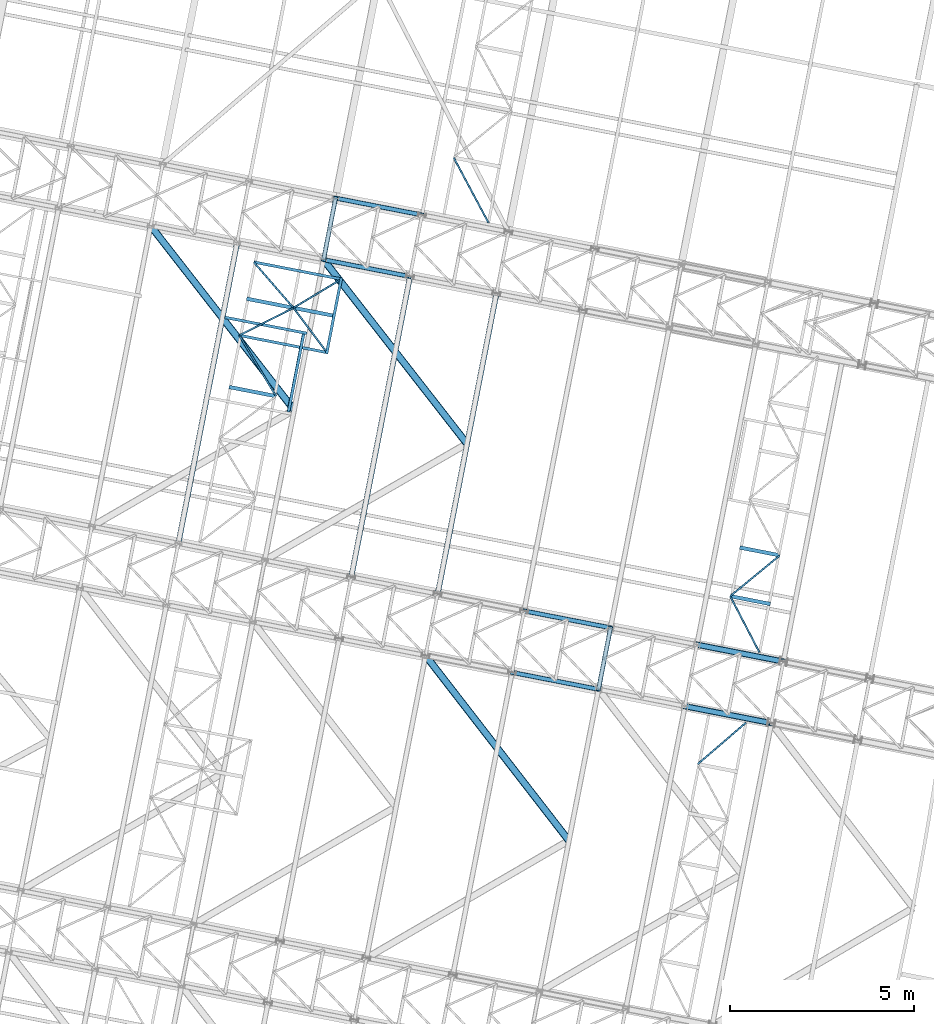
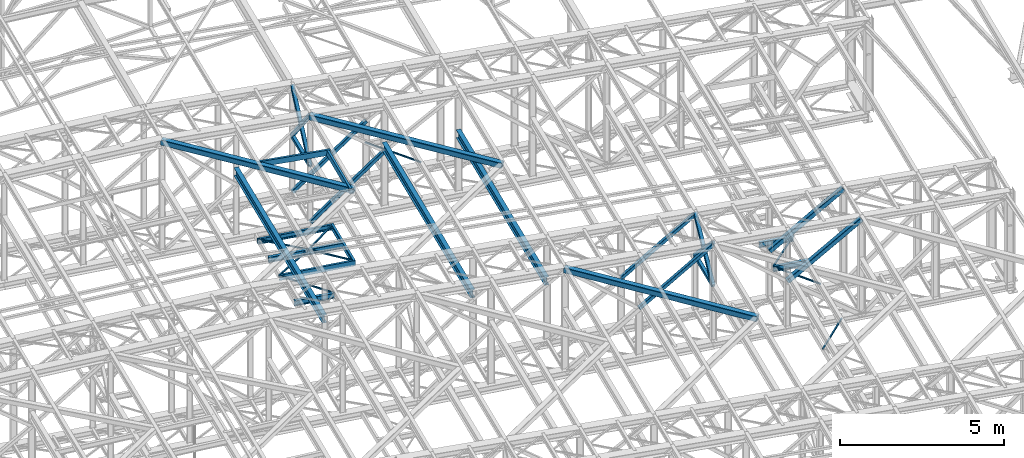
# One storey, part 91 of 215: 26 beams, 10 members, 36 elements without a shape of their own.
"""IFC2X3 building model written with IfcOpenShell, lengths in millimetres."""

from ifc_helpers import new_model, si_unit, frame, origin_with_axes, origin_2d_with_axis, place, context, subcontext, project, spatial, hollow_rectangle, i_section, u_section, extrude, material, type_object, element, aggregate, save


model = new_model("IFC2X3")

# Units and contexts
model_context = context("Model", 3, precision=1e-05, world=origin_with_axes())
body_context = subcontext(model_context, "Body", "Model", "MODEL_VIEW")
ifc_project = project(units=[si_unit("LENGTHUNIT", "METRE", prefix="MILLI"), si_unit("AREAUNIT", "SQUARE_METRE"), si_unit("VOLUMEUNIT", "CUBIC_METRE"), si_unit("MASSUNIT", "GRAM", prefix="KILO"), si_unit("TIMEUNIT", "SECOND"), si_unit("PLANEANGLEUNIT", "RADIAN"), si_unit("SOLIDANGLEUNIT", "STERADIAN"), si_unit("THERMODYNAMICTEMPERATUREUNIT", "DEGREE_CELSIUS"), si_unit("LUMINOUSINTENSITYUNIT", "LUMEN")], contexts=[model_context])

# Site, building, storey
site_placement = place(None, origin_with_axes())
site = spatial("IfcSite", under=ifc_project, at=site_placement, CompositionType="ELEMENT")
building_placement = place(site_placement, origin_with_axes())
building = spatial("IfcBuilding", under=site, at=building_placement, Name="Undefined", CompositionType="ELEMENT")
storey_placement = place(building_placement, origin_with_axes())
storey = spatial("IfcBuildingStorey", under=building, at=storey_placement, Name="Undefined", CompositionType="ELEMENT", Elevation=0.0)

# Assembly, beam
assembly_1_placement = place(storey_placement, origin_with_axes())
assembly_1 = element("IfcElementAssembly", 1, at=assembly_1_placement, inside=storey, Name="Steel Assembly", AssemblyPlace="NOTDEFINED", PredefinedType="RIGID_FRAME")
ifc_material_1 = material(Name="STEEL/S275JR")
beam_type_1 = type_object("IfcBeamType", PredefinedType="NOTDEFINED")
beam_1_placement = place(assembly_1_placement, frame((85110.1188947794, 34374.6074251292, 10796.000000583), z_axis=(0.981422364268518, -0.191859461052493, -0.000300197000082615), x_axis=(0.191859470081235, 0.981422408415534, 0.0)))
beam_1 = element("IfcBeam", 2, at=beam_1_placement, type_object=beam_type_1, material=ifc_material_1, context=body_context, shape_type="SweptSolid", body=[
    extrude(hollow_rectangle(XDim=120.0, YDim=120.0, WallThickness=5.0, InnerFilletRadius=5.0, OuterFilletRadius=10.0, at=origin_2d_with_axis()), frame((1699.99999941724, 1.81898940354586e-12, 0.0), z_axis=(-1.0, 0.0, 0.0), x_axis=(-6.93889390390723e-18, -1.0, -3.46944695195361e-18)), (0.0, 0.0, 1.0), 1700.0),
])
aggregate(assembly_1, [beam_1])

assembly_2_placement = place(storey_placement, origin_with_axes())
assembly_2 = element("IfcElementAssembly", 3, at=assembly_2_placement, inside=storey, Name="Steel Assembly", AssemblyPlace="NOTDEFINED", PredefinedType="RIGID_FRAME")
beam_2_placement = place(assembly_2_placement, frame((77653.7399053253, 46028.0306050497, 10796.0000008389), z_axis=(0.981422364268518, -0.191859461052493, -0.000300197000082615), x_axis=(0.191859470081235, 0.981422408415534, 0.0)))
beam_2 = element("IfcBeam", 4, at=beam_2_placement, type_object=beam_type_1, material=ifc_material_1, context=body_context, shape_type="SweptSolid", body=[
    extrude(hollow_rectangle(XDim=120.0, YDim=120.0, WallThickness=5.0, InnerFilletRadius=5.0, OuterFilletRadius=10.0, at=origin_2d_with_axis()), frame((1699.99999941724, 1.81898940354586e-12, 0.0), z_axis=(-1.0, 0.0, 0.0), x_axis=(-6.93889390390723e-18, -1.0, -3.46944695195361e-18)), (0.0, 0.0, 1.0), 1700.0),
])
aggregate(assembly_2, [beam_2])

assembly_3_placement = place(storey_placement, origin_with_axes())
assembly_3 = element("IfcElementAssembly", 5, at=assembly_3_placement, inside=storey, Name="Steel Assembly", AssemblyPlace="NOTDEFINED", PredefinedType="RIGID_FRAME")
beam_type_2 = type_object("IfcBeamType", PredefinedType="NOTDEFINED")
beam_3_placement = place(assembly_3_placement, frame((78086.7238585215, 45469.5974852065, 8745.0), z_axis=(0.0, 0.0, -1.0), x_axis=(-0.85752514191365, -0.514442057948195, 0.0)))
beam_3 = element("IfcBeam", 6, at=beam_3_placement, type_object=beam_type_2, material=ifc_material_1, context=body_context, shape_type="SweptSolid", body=[
    extrude(hollow_rectangle(XDim=50.0, YDim=50.0, WallThickness=3.0, InnerFilletRadius=3.0, OuterFilletRadius=6.0, at=origin_2d_with_axis()), frame((1457.52347503304, -2.27373675443232e-13, 0.0), z_axis=(-1.0, 0.0, 0.0), x_axis=(-6.93889390390723e-18, -1.0, -3.46944695195361e-18)), (0.0, 0.0, 1.0), 1457.5),
])
aggregate(assembly_3, [beam_3])

assembly_4_placement = place(storey_placement, origin_with_axes())
assembly_4 = element("IfcElementAssembly", 7, at=assembly_4_placement, inside=storey, Name="Steel Assembly", AssemblyPlace="NOTDEFINED", PredefinedType="RIGID_FRAME")
beam_4_placement = place(assembly_4_placement, frame((76836.8608344988, 44719.7861078269, 8745.0), z_axis=(0.0, 0.0, -1.0), x_axis=(0.600292793883788, -0.799780320845166, 0.0)))
beam_4 = element("IfcBeam", 8, at=beam_4_placement, type_object=beam_type_2, material=ifc_material_1, context=body_context, shape_type="SweptSolid", body=[
    extrude(hollow_rectangle(XDim=50.0, YDim=50.0, WallThickness=3.0, InnerFilletRadius=3.0, OuterFilletRadius=6.0, at=origin_2d_with_axis()), frame((1458.12779217383, 2.42827057157585e-13, 0.0), z_axis=(-1.0, 0.0, 0.0), x_axis=(-6.93889390390723e-18, -1.0, -3.46944695195361e-18)), (0.0, 0.0, 1.0), 1458.1),
])
aggregate(assembly_4, [beam_4])

assembly_5_placement = place(storey_placement, origin_with_axes())
assembly_5 = element("IfcElementAssembly", 9, at=assembly_5_placement, inside=storey, Name="Steel Assembly", AssemblyPlace="NOTDEFINED", PredefinedType="RIGID_FRAME")
beam_5_placement = place(assembly_5_placement, frame((88680.9563793763, 36900.832059643, 8705.0), z_axis=(0.0, 0.0, -1.0), x_axis=(0.461445921849005, -0.887168338709696, 0.0)))
beam_5 = element("IfcBeam", 10, at=beam_5_placement, type_object=beam_type_2, material=ifc_material_1, context=body_context, shape_type="SweptSolid", body=[
    extrude(hollow_rectangle(XDim=50.0, YDim=50.0, WallThickness=3.0, InnerFilletRadius=3.0, OuterFilletRadius=6.0, at=origin_2d_with_axis()), frame((1718.74516213938, 0.0, 0.0), z_axis=(-1.0, 0.0, 0.0), x_axis=(-6.93889390390723e-18, -1.0, -3.46944695195361e-18)), (0.0, 0.0, 1.0), 1718.7),
])
aggregate(assembly_5, [beam_5])

assembly_6_placement = place(storey_placement, origin_with_axes())
assembly_6 = element("IfcElementAssembly", 11, at=assembly_6_placement, inside=storey, Name="Steel Assembly", AssemblyPlace="NOTDEFINED", PredefinedType="RIGID_FRAME")
beam_6_placement = place(assembly_6_placement, frame((90027.6693775793, 38007.6995695426, 8705.0), z_axis=(0.0, 0.0, -1.0), x_axis=(-0.772546438116603, -0.634958267095838, 0.0)))
beam_6 = element("IfcBeam", 12, at=beam_6_placement, type_object=beam_type_2, material=ifc_material_1, context=body_context, shape_type="SweptSolid", body=[
    extrude(hollow_rectangle(XDim=50.0, YDim=50.0, WallThickness=3.0, InnerFilletRadius=3.0, OuterFilletRadius=6.0, at=origin_2d_with_axis()), frame((1743.21300586829, -3.34767552470056e-12, 0.0), z_axis=(-1.0, 0.0, 0.0), x_axis=(-6.93889390390723e-18, -1.0, -3.46944695195361e-18)), (0.0, 0.0, 1.0), 1743.2),
])
aggregate(assembly_6, [beam_6])

assembly_7_placement = place(storey_placement, origin_with_axes())
assembly_7 = element("IfcElementAssembly", 13, at=assembly_7_placement, inside=storey, Name="Steel Assembly", AssemblyPlace="NOTDEFINED", PredefinedType="RIGID_FRAME")
beam_7_placement = place(assembly_7_placement, frame((89109.3306253253, 33470.5354370162, 8705.0), z_axis=(0.0, 0.0, -1.0), x_axis=(-0.758731425258215, -0.651403580221692, 0.0)))
beam_7 = element("IfcBeam", 14, at=beam_7_placement, type_object=beam_type_2, material=ifc_material_1, context=body_context, shape_type="SweptSolid", body=[
    extrude(hollow_rectangle(XDim=50.0, YDim=50.0, WallThickness=3.0, InnerFilletRadius=3.0, OuterFilletRadius=6.0, at=origin_2d_with_axis()), frame((1724.58319108664, -7.08449041752084e-12, 0.0), z_axis=(-1.0, 0.0, 0.0), x_axis=(-6.93889390390723e-18, -1.0, -3.46944695195361e-18)), (0.0, 0.0, 1.0), 1724.6),
])
aggregate(assembly_7, [beam_7])

assembly_8_placement = place(storey_placement, origin_with_axes())
assembly_8 = element("IfcElementAssembly", 15, at=assembly_8_placement, inside=storey, Name="Steel Assembly", AssemblyPlace="NOTDEFINED", PredefinedType="RIGID_FRAME")
beam_8_placement = place(assembly_8_placement, frame((81181.9931692412, 48795.4280107107, 8745.0), z_axis=(0.0, 0.0, -1.0), x_axis=(0.470944750972681, -0.882162706948825, 0.0)))
beam_8 = element("IfcBeam", 16, at=beam_8_placement, type_object=beam_type_2, material=ifc_material_1, context=body_context, shape_type="SweptSolid", body=[
    extrude(hollow_rectangle(XDim=50.0, YDim=50.0, WallThickness=3.0, InnerFilletRadius=3.0, OuterFilletRadius=6.0, at=origin_2d_with_axis()), frame((2002.67768466056, 0.0, 0.0), z_axis=(-1.0, 0.0, 0.0), x_axis=(-6.93889390390723e-18, -1.0, -3.46944695195361e-18)), (0.0, 0.0, 1.0), 2002.7),
])
aggregate(assembly_8, [beam_8])

assembly_9_placement = place(storey_placement, origin_with_axes())
assembly_9 = element("IfcElementAssembly", 17, at=assembly_9_placement, inside=storey, Name="Steel Assembly", AssemblyPlace="NOTDEFINED", PredefinedType="RIGID_FRAME")
beam_9_placement = place(assembly_9_placement, frame((75369.1529665994, 43973.8755347454, 8745.0), z_axis=(0.0, 0.0, -1.0), x_axis=(0.516879869981266, -0.856057941968971, 0.0)))
beam_9 = element("IfcBeam", 18, at=beam_9_placement, type_object=beam_type_2, material=ifc_material_1, context=body_context, shape_type="SweptSolid", body=[
    extrude(hollow_rectangle(XDim=50.0, YDim=50.0, WallThickness=3.0, InnerFilletRadius=3.0, OuterFilletRadius=6.0, at=origin_2d_with_axis()), frame((1927.1552168636, 1.45519152283669e-11, -1.81898940354586e-12), z_axis=(-1.0, 0.0, 0.0), x_axis=(-6.93889390390723e-18, -1.0, -3.46944695195361e-18)), (0.0, 0.0, 1.0), 1927.2),
])
aggregate(assembly_9, [beam_9])

assembly_10_placement = place(storey_placement, origin_with_axes())
assembly_10 = element("IfcElementAssembly", 19, at=assembly_10_placement, inside=storey, Name="Steel Assembly", AssemblyPlace="NOTDEFINED", PredefinedType="RIGID_FRAME")
beam_10_placement = place(assembly_10_placement, frame((76836.8608344988, 44719.7861078269, 8745.0), z_axis=(0.0, 0.0, -1.0), x_axis=(-0.891478746095286, -0.453062518048423, 0.0)))
beam_10 = element("IfcBeam", 20, at=beam_10_placement, type_object=beam_type_2, material=ifc_material_1, context=body_context, shape_type="SweptSolid", body=[
    extrude(hollow_rectangle(XDim=50.0, YDim=50.0, WallThickness=3.0, InnerFilletRadius=3.0, OuterFilletRadius=6.0, at=origin_2d_with_axis()), frame((1646.37449218839, -9.13921434191551e-14, 0.0), z_axis=(-1.0, 0.0, 0.0), x_axis=(-6.93889390390723e-18, -1.0, -3.46944695195361e-18)), (0.0, 0.0, 1.0), 1646.4),
])
aggregate(assembly_10, [beam_10])

assembly_11_placement = place(storey_placement, origin_with_axes())
assembly_11 = element("IfcElementAssembly", 21, at=assembly_11_placement, inside=storey, Name="Steel Assembly", AssemblyPlace="NOTDEFINED", PredefinedType="RIGID_FRAME")
beam_11_placement = place(assembly_11_placement, frame((75763.4566323423, 45958.0807780043, 8745.0), z_axis=(0.0, 0.0, -1.0), x_axis=(0.655005626745312, -0.755623999706191, 0.0)))
beam_11 = element("IfcBeam", 22, at=beam_11_placement, type_object=beam_type_2, material=ifc_material_1, context=body_context, shape_type="SweptSolid", body=[
    extrude(hollow_rectangle(XDim=50.0, YDim=50.0, WallThickness=3.0, InnerFilletRadius=3.0, OuterFilletRadius=6.0, at=origin_2d_with_axis()), frame((1638.77096367879, 1.44609451655687e-11, 0.0), z_axis=(-1.0, 0.0, 0.0), x_axis=(-6.93889390390723e-18, -1.0, -3.46944695195361e-18)), (0.0, 0.0, 1.0), 1638.8),
])
aggregate(assembly_11, [beam_11])

assembly_12_placement = place(storey_placement, origin_with_axes())
assembly_12 = element("IfcElementAssembly", 23, at=assembly_12_placement, inside=storey, Name="Steel Assembly", AssemblyPlace="NOTDEFINED", PredefinedType="RIGID_FRAME")
ifc_material_2 = material(Name="STEEL/S235JR")
beam_type_3 = type_object("IfcBeamType", Name="UPN200", PredefinedType="NOTDEFINED")
beam_12_placement = place(assembly_12_placement, frame((76698.5892814045, 41897.7374630307, 12676.1640055979), z_axis=(0.0304080349965938, -0.00594450399933318, 0.999519891888024), x_axis=(0.191859470081235, 0.981422408415534, 0.0)))
beam_12 = element("IfcBeam", 24, at=beam_12_placement, type_object=beam_type_3, material=ifc_material_2, ObjectType="UPN200", context=body_context, shape_type="SweptSolid", body=[
    extrude(u_section(Depth=200.0, FlangeWidth=75.0, WebThickness=8.5, FlangeThickness=11.5, FilletRadius=11.5, EdgeRadius=6.0, FlangeSlope=0.0798299857122373, at=origin_2d_with_axis()), frame((2149.96645748991, 6.98418044224936e-15, -1.81533901666633e-12), z_axis=(-1.0, 0.0, 0.0), x_axis=(-6.93889390390723e-18, -1.0, -3.46944695195361e-18)), (0.0, 0.0, 1.0), 2150.0),
])
aggregate(assembly_12, [beam_12])

assembly_13_placement = place(storey_placement, origin_with_axes())
assembly_13 = element("IfcElementAssembly", 25, at=assembly_13_placement, inside=storey, Name="Steel Assembly", AssemblyPlace="NOTDEFINED", PredefinedType="RIGID_FRAME")
beam_13_placement = place(assembly_13_placement, frame((77198.7828265451, 44028.8374695001, 12673.6399439861), z_axis=(0.0304080349965938, -0.00594450399933318, 0.999519891888024), x_axis=(-0.980947274706054, 0.19178753394253, 0.030983641990716)))
beam_13 = element("IfcBeam", 26, at=beam_13_placement, type_object=beam_type_3, material=ifc_material_2, ObjectType="UPN200", context=body_context, shape_type="SweptSolid", body=[
    extrude(u_section(Depth=200.0, FlangeWidth=75.0, WebThickness=8.5, FlangeThickness=11.5, FilletRadius=11.5, EdgeRadius=6.0, FlangeSlope=0.0798299857122373, at=origin_2d_with_axis()), frame((2269.56619159897, -1.00164711038344e-14, -7.87413950570001e-15), z_axis=(-1.0, 0.0, 0.0), x_axis=(-6.93889390390723e-18, -1.0, -3.46944695195361e-18)), (0.0, 0.0, 1.0), 2269.6),
])
aggregate(assembly_13, [beam_13])

assembly_14_placement = place(storey_placement, origin_with_axes())
assembly_14 = element("IfcElementAssembly", 27, at=assembly_14_placement, inside=storey, Name="Steel Assembly", AssemblyPlace="NOTDEFINED", PredefinedType="RIGID_FRAME")
beam_14_placement = place(assembly_14_placement, frame((75369.1528952898, 43973.8755492501, 8670.00000003361), z_axis=(0.0, 0.0, -1.0), x_axis=(0.981387333791384, -0.192038800959178, 0.0)))
beam_14 = element("IfcBeam", 28, at=beam_14_placement, type_object=beam_type_3, material=ifc_material_1, ObjectType="UPN200", context=body_context, shape_type="SweptSolid", body=[
    extrude(u_section(Depth=200.0, FlangeWidth=75.0, WebThickness=8.5, FlangeThickness=11.5, FilletRadius=11.5, EdgeRadius=6.0, FlangeSlope=0.0798299857122373, at=origin_2d_with_axis()), frame((2455.1239841767, -6.81433793885606e-14, 0.0), z_axis=(-1.0, 0.0, 0.0), x_axis=(-6.93889390390723e-18, -1.0, -3.46944695195361e-18)), (0.0, 0.0, 1.0), 2455.1),
])
aggregate(assembly_14, [beam_14])

assembly_15_placement = place(storey_placement, origin_with_axes())
assembly_15 = element("IfcElementAssembly", 29, at=assembly_15_placement, inside=storey, Name="Steel Assembly", AssemblyPlace="NOTDEFINED", PredefinedType="RIGID_FRAME")
beam_15_placement = place(assembly_15_placement, frame((78167.5162461311, 45491.9996862988, 8670.00000000005), z_axis=(0.0, 0.0, -1.0), x_axis=(-0.981388638953544, 0.19203213099091, 0.0)))
beam_15 = element("IfcBeam", 30, at=beam_15_placement, type_object=beam_type_3, material=ifc_material_1, ObjectType="UPN200", context=body_context, shape_type="SweptSolid", body=[
    extrude(u_section(Depth=200.0, FlangeWidth=75.0, WebThickness=8.5, FlangeThickness=11.5, FilletRadius=11.5, EdgeRadius=6.0, FlangeSlope=0.0798299857122373, at=origin_2d_with_axis()), frame((2448.81926269029, 0.0, 0.0), z_axis=(-1.0, 0.0, 0.0), x_axis=(-6.93889390390723e-18, -1.0, -3.46944695195361e-18)), (0.0, 0.0, 1.0), 2448.8),
])
aggregate(assembly_15, [beam_15])

assembly_16_placement = place(storey_placement, origin_with_axes())
assembly_16 = element("IfcElementAssembly", 31, at=assembly_16_placement, inside=storey, Name="Steel Assembly", AssemblyPlace="NOTDEFINED", PredefinedType="RIGID_FRAME")
beam_16_placement = place(assembly_16_placement, frame((77734.5756790587, 43472.7891786347, 8670.00000003361), z_axis=(0.0, 0.0, -1.0), x_axis=(0.191859470081235, 0.981422408415534, 0.0)))
beam_16 = element("IfcBeam", 32, at=beam_16_placement, type_object=beam_type_3, material=ifc_material_1, ObjectType="UPN200", context=body_context, shape_type="SweptSolid", body=[
    extrude(u_section(Depth=200.0, FlangeWidth=75.0, WebThickness=8.5, FlangeThickness=11.5, FilletRadius=11.5, EdgeRadius=6.0, FlangeSlope=0.0798299857122373, at=origin_2d_with_axis()), frame((2102.26217859175, 0.0, 0.0), z_axis=(-1.0, 0.0, 0.0), x_axis=(-6.93889390390723e-18, -1.0, -3.46944695195361e-18)), (0.0, 0.0, 1.0), 2102.3),
])
aggregate(assembly_16, [beam_16])

# Assembly, member
assembly_17_placement = place(storey_placement, origin_with_axes())
assembly_17 = element("IfcElementAssembly", 33, at=assembly_17_placement, inside=storey, Name="Steel Assembly", AssemblyPlace="NOTDEFINED", PredefinedType="RIGID_FRAME")
member_type_1 = type_object("IfcMemberType", PredefinedType="NOTDEFINED")
member_1_placement = place(assembly_17_placement, frame((85436.2799930333, 36043.025518972, 10796.0000007861), z_axis=(0.981461701624211, -0.19165823792662, 0.000219270999915979), x_axis=(-0.140138869039808, -0.716855033203644, 0.682993381194025)))
member_1 = element("IfcMember", 34, at=member_1_placement, type_object=member_type_1, material=ifc_material_1, context=body_context, shape_type="SweptSolid", body=[
    extrude(hollow_rectangle(XDim=120.0, YDim=120.0, WallThickness=5.0, InnerFilletRadius=5.0, OuterFilletRadius=10.0, at=origin_2d_with_axis()), frame((2327.41350452431, -7.27595761418343e-12, -1.06739260704213e-13), z_axis=(-1.0, 0.0, 0.0), x_axis=(-6.93889390390723e-18, -1.0, -3.46944695195361e-18)), (0.0, 0.0, 1.0), 2327.4),
])
aggregate(assembly_17, [member_1])

assembly_18_placement = place(storey_placement, origin_with_axes())
assembly_18 = element("IfcElementAssembly", 35, at=assembly_18_placement, inside=storey, Name="Steel Assembly", AssemblyPlace="NOTDEFINED", PredefinedType="RIGID_FRAME")
member_2_placement = place(assembly_18_placement, frame((85110.1188947794, 34374.6074251292, 10796.000000583), z_axis=(0.981461701624211, -0.19165823792662, -0.000219270999915979), x_axis=(0.140138870001192, 0.716855037006089, 0.682993377005801)))
member_2 = element("IfcMember", 36, at=member_2_placement, type_object=member_type_1, material=ifc_material_1, context=body_context, shape_type="SweptSolid", body=[
    extrude(hollow_rectangle(XDim=120.0, YDim=120.0, WallThickness=5.0, InnerFilletRadius=5.0, OuterFilletRadius=10.0, at=origin_2d_with_axis()), frame((2327.41350452431, -7.27595761418343e-12, -1.06739260704213e-13), z_axis=(-1.0, 0.0, 0.0), x_axis=(-6.93889390390723e-18, -1.0, -3.46944695195361e-18)), (0.0, 0.0, 1.0), 2327.4),
])
aggregate(assembly_18, [member_2])

assembly_19_placement = place(storey_placement, origin_with_axes())
assembly_19 = element("IfcElementAssembly", 37, at=assembly_19_placement, inside=storey, Name="Steel Assembly", AssemblyPlace="NOTDEFINED", PredefinedType="RIGID_FRAME")
member_3_placement = place(assembly_19_placement, frame((77979.9010039897, 47696.448698864, 10796.0000008371), z_axis=(0.981465144014204, -0.191640629002775, 0.000200999000003501), x_axis=(-0.128461058963395, -0.657119307812757, 0.742759699788354)))
member_3 = element("IfcMember", 38, at=member_3_placement, type_object=member_type_1, material=ifc_material_1, context=body_context, shape_type="SweptSolid", body=[
    extrude(hollow_rectangle(XDim=120.0, YDim=120.0, WallThickness=5.0, InnerFilletRadius=5.0, OuterFilletRadius=10.0, at=origin_2d_with_axis()), frame((2538.98807297308, -7.4168997650766e-12, -1.4616192556948e-11), z_axis=(-1.0, 0.0, 0.0), x_axis=(-6.93889390390723e-18, -1.0, -3.46944695195361e-18)), (0.0, 0.0, 1.0), 2539.0),
])
aggregate(assembly_19, [member_3])

assembly_20_placement = place(storey_placement, origin_with_axes())
assembly_20 = element("IfcElementAssembly", 39, at=assembly_20_placement, inside=storey, Name="Steel Assembly", AssemblyPlace="NOTDEFINED", PredefinedType="RIGID_FRAME")
member_4_placement = place(assembly_20_placement, frame((77653.7399053253, 46028.0306050497, 10796.0000008389), z_axis=(0.981465144014204, -0.191640629002775, -0.000200999000003501), x_axis=(0.128461059990898, 0.657119311953447, 0.742759695947379)))
member_4 = element("IfcMember", 40, at=member_4_placement, type_object=member_type_1, material=ifc_material_1, context=body_context, shape_type="SweptSolid", body=[
    extrude(hollow_rectangle(XDim=120.0, YDim=120.0, WallThickness=5.0, InnerFilletRadius=5.0, OuterFilletRadius=10.0, at=origin_2d_with_axis()), frame((2538.98807297308, -7.4168997650766e-12, -1.4616192556948e-11), z_axis=(-1.0, 0.0, 0.0), x_axis=(-6.93889390390723e-18, -1.0, -3.46944695195361e-18)), (0.0, 0.0, 1.0), 2539.0),
])
aggregate(assembly_20, [member_4])

assembly_21_placement = place(storey_placement, origin_with_axes())
assembly_21 = element("IfcElementAssembly", 41, at=assembly_21_placement, inside=storey, Name="Steel Assembly", AssemblyPlace="NOTDEFINED", PredefinedType="RIGID_FRAME")
member_5_placement = place(assembly_21_placement, frame((77984.7794890332, 47695.495090752, 8689.99756455283), z_axis=(0.649815790842524, -0.127044508969211, -0.749399179818391), x_axis=(0.735477150740993, -0.143779314949367, 0.662118470766827)))
member_5 = element("IfcMember", 42, at=member_5_placement, type_object=member_type_1, material=ifc_material_1, context=body_context, shape_type="SweptSolid", body=[
    extrude(hollow_rectangle(XDim=120.0, YDim=120.0, WallThickness=5.0, InnerFilletRadius=5.0, OuterFilletRadius=10.0, at=origin_2d_with_axis()), frame((3180.70334731965, 1.44811396312274e-11, 7.45252211871826e-12), z_axis=(-1.0, 0.0, 0.0), x_axis=(-6.93889390390723e-18, -1.0, -3.46944695195361e-18)), (0.0, 0.0, 1.0), 3180.7),
])
aggregate(assembly_21, [member_5])

assembly_22_placement = place(storey_placement, origin_with_axes())
assembly_22 = element("IfcElementAssembly", 43, at=assembly_22_placement, inside=storey, Name="Steel Assembly", AssemblyPlace="NOTDEFINED", PredefinedType="RIGID_FRAME")
member_6_placement = place(assembly_22_placement, frame((77658.6184219601, 46027.0769900694, 8689.99756455283), z_axis=(0.649815790842524, -0.127044508969211, -0.749399179818391), x_axis=(0.735477150740993, -0.143779314949367, 0.662118470766827)))
member_6 = element("IfcMember", 44, at=member_6_placement, type_object=member_type_1, material=ifc_material_1, context=body_context, shape_type="SweptSolid", body=[
    extrude(hollow_rectangle(XDim=120.0, YDim=120.0, WallThickness=5.0, InnerFilletRadius=5.0, OuterFilletRadius=10.0, at=origin_2d_with_axis()), frame((3180.70334731965, 1.44811396312274e-11, 7.45252211871826e-12), z_axis=(-1.0, 0.0, 0.0), x_axis=(-6.93889390390723e-18, -1.0, -3.46944695195361e-18)), (0.0, 0.0, 1.0), 3180.7),
])
aggregate(assembly_22, [member_6])

assembly_23_placement = place(storey_placement, origin_with_axes())
assembly_23 = element("IfcElementAssembly", 45, at=assembly_23_placement, inside=storey, Name="Steel Assembly", AssemblyPlace="NOTDEFINED", PredefinedType="RIGID_FRAME")
member_7_placement = place(assembly_23_placement, frame((83089.6029802746, 36501.7803137055, 10487.6154503376), z_axis=(0.597857237183729, -0.116875832035918, -0.793036420243705), x_axis=(0.778303714010845, -0.15215154400212, 0.609174225008491)))
member_7 = element("IfcMember", 46, at=member_7_placement, type_object=member_type_1, material=ifc_material_1, context=body_context, shape_type="SweptSolid", body=[
    extrude(hollow_rectangle(XDim=120.0, YDim=120.0, WallThickness=5.0, InnerFilletRadius=5.0, OuterFilletRadius=10.0, at=origin_2d_with_axis()), frame((3009.06048309865, 4.17887832065349e-14, 1.67036411541291e-13), z_axis=(-1.0, 0.0, 0.0), x_axis=(-6.93889390390723e-18, -1.0, -3.46944695195361e-18)), (0.0, 0.0, 1.0), 3009.1),
])
aggregate(assembly_23, [member_7])

assembly_24_placement = place(storey_placement, origin_with_axes())
assembly_24 = element("IfcElementAssembly", 47, at=assembly_24_placement, inside=storey, Name="Steel Assembly", AssemblyPlace="NOTDEFINED", PredefinedType="RIGID_FRAME")
member_8_placement = place(assembly_24_placement, frame((82763.5732596985, 34833.3365359363, 10487.7182545766), z_axis=(0.597857237183729, -0.116875832035918, -0.793036420243705), x_axis=(0.778303714010845, -0.15215154400212, 0.609174225008491)))
member_8 = element("IfcMember", 48, at=member_8_placement, type_object=member_type_1, material=ifc_material_1, context=body_context, shape_type="SweptSolid", body=[
    extrude(hollow_rectangle(XDim=120.0, YDim=120.0, WallThickness=5.0, InnerFilletRadius=5.0, OuterFilletRadius=10.0, at=origin_2d_with_axis()), frame((3008.89172309029, -7.23034031615645e-12, 1.67027043478946e-13), z_axis=(-1.0, 0.0, 0.0), x_axis=(-6.93889390390723e-18, -1.0, -3.46944695195361e-18)), (0.0, 0.0, 1.0), 3008.9),
])
aggregate(assembly_24, [member_8])

# Assembly, beam
assembly_25_placement = place(storey_placement, origin_with_axes())
assembly_25 = element("IfcElementAssembly", 49, at=assembly_25_placement, inside=storey, Name="Steel Assembly", AssemblyPlace="NOTDEFINED", PredefinedType="RIGID_FRAME")
beam_type_4 = type_object("IfcBeamType", PredefinedType="NOTDEFINED")
beam_17_placement = place(assembly_25_placement, frame((76852.9528340433, 41952.7841784777, 12638.8183881466), z_axis=(0.0303361180133672, -0.00559522800246258, 0.999524093440213), x_axis=(-0.614590197031211, 0.788509224040042, 0.0230671480011714)))
beam_17 = element("IfcBeam", 50, at=beam_17_placement, type_object=beam_type_4, material=ifc_material_1, context=body_context, shape_type="SweptSolid", body=[
    extrude(hollow_rectangle(XDim=200.0, YDim=200.0, WallThickness=10.0, InnerFilletRadius=15.0, OuterFilletRadius=25.0, at=origin_2d_with_axis()), frame((6331.58647738603, -9.79595517466615e-13, 2.19671034049977e-14), z_axis=(-1.0, 0.0, 0.0), x_axis=(-6.93889390390723e-18, -1.0, -3.46944695195361e-18)), (0.0, 0.0, 1.0), 6331.6),
])
aggregate(assembly_25, [beam_17])

assembly_26_placement = place(storey_placement, origin_with_axes())
assembly_26 = element("IfcElementAssembly", 51, at=assembly_26_placement, inside=storey, Name="Steel Assembly", AssemblyPlace="NOTDEFINED", PredefinedType="RIGID_FRAME")
beam_18_placement = place(assembly_26_placement, frame((81541.0485687793, 41036.3025601632, 12490.7434891767), z_axis=(0.0303361180133672, -0.00559522800246258, 0.999524093440213), x_axis=(-0.614590197031211, 0.788509224040042, 0.0230671480011714)))
beam_18 = element("IfcBeam", 52, at=beam_18_placement, type_object=beam_type_4, material=ifc_material_1, context=body_context, shape_type="SweptSolid", body=[
    extrude(hollow_rectangle(XDim=200.0, YDim=200.0, WallThickness=10.0, InnerFilletRadius=15.0, OuterFilletRadius=25.0, at=origin_2d_with_axis()), frame((6331.58647738603, -9.79595517466615e-13, 2.19671034049977e-14), z_axis=(-1.0, 0.0, 0.0), x_axis=(-6.93889390390723e-18, -1.0, -3.46944695195361e-18)), (0.0, 0.0, 1.0), 6331.6),
])
aggregate(assembly_26, [beam_18])

assembly_27_placement = place(storey_placement, origin_with_axes())
assembly_27 = element("IfcElementAssembly", 53, at=assembly_27_placement, inside=storey, Name="Steel Assembly", AssemblyPlace="NOTDEFINED", PredefinedType="RIGID_FRAME")
beam_19_placement = place(assembly_27_placement, frame((84304.0148119806, 30272.606619915, 12342.6711990047), z_axis=(0.0303378029878793, -0.00559570999776539, 0.999524039600594), x_axis=(-0.612030851936216, 0.790499299917617, 0.0230020239976028)))
beam_19 = element("IfcBeam", 54, at=beam_19_placement, type_object=beam_type_4, material=ifc_material_1, context=body_context, shape_type="SweptSolid", body=[
    extrude(hollow_rectangle(XDim=200.0, YDim=200.0, WallThickness=10.0, InnerFilletRadius=15.0, OuterFilletRadius=25.0, at=origin_2d_with_axis()), frame((6349.51246722592, -6.06494074105851e-13, -1.81898940354586e-12), z_axis=(-1.0, 0.0, 0.0), x_axis=(-6.93889390390723e-18, -1.0, -3.46944695195361e-18)), (0.0, 0.0, 1.0), 6349.5),
])
aggregate(assembly_27, [beam_19])

assembly_28_placement = place(storey_placement, origin_with_axes())
assembly_28 = element("IfcElementAssembly", 55, at=assembly_28_placement, inside=storey, Name="Steel Assembly", AssemblyPlace="NOTDEFINED", PredefinedType="RIGID_FRAME")
beam_type_5 = type_object("IfcBeamType", Name="IPE300", PredefinedType="NOTDEFINED")
beam_20_placement = place(assembly_28_placement, frame((80748.1876007316, 36959.5064506544, 10901.7000000974), z_axis=(0.0, 0.0, 1.0), x_axis=(0.191879342079262, 0.981418523405397, 1.00000006478113e-09)))
beam_20 = element("IfcBeam", 56, at=beam_20_placement, type_object=beam_type_5, material=ifc_material_1, Name="SUPPORT", ObjectType="IPE300", context=body_context, shape_type="SweptSolid", body=[
    extrude(i_section(OverallWidth=150.0, OverallDepth=300.0, WebThickness=7.099999905, FlangeThickness=10.69999981, FilletRadius=15.0, at=origin_2d_with_axis()), frame((8306.35394615426, -2.30547635042662e-13, -1.81898940354586e-12), z_axis=(-1.0, 0.0, 0.0), x_axis=(-6.93889390390723e-18, -1.0, -3.46944695195361e-18)), (0.0, 0.0, 1.0), 8306.4),
])
aggregate(assembly_28, [beam_20])

assembly_29_placement = place(storey_placement, origin_with_axes())
assembly_29 = element("IfcElementAssembly", 57, at=assembly_29_placement, inside=storey, Name="Steel Assembly", AssemblyPlace="NOTDEFINED", PredefinedType="RIGID_FRAME")
beam_21_placement = place(assembly_29_placement, frame((78404.1397197412, 37417.7471976497, 10975.7300001147), z_axis=(0.0, 0.0, 1.0), x_axis=(0.191879342079262, 0.981418523405397, 1.00000006478113e-09)))
beam_21 = element("IfcBeam", 58, at=beam_21_placement, type_object=beam_type_5, material=ifc_material_1, Name="SUPPORT", ObjectType="IPE300", context=body_context, shape_type="SweptSolid", body=[
    extrude(i_section(OverallWidth=150.0, OverallDepth=300.0, WebThickness=7.099999905, FlangeThickness=10.69999981, FilletRadius=15.0, at=origin_2d_with_axis()), frame((8306.35394615426, -2.30547635042662e-13, -1.81898940354586e-12), z_axis=(-1.0, 0.0, 0.0), x_axis=(-6.93889390390723e-18, -1.0, -3.46944695195361e-18)), (0.0, 0.0, 1.0), 8306.4),
])
aggregate(assembly_29, [beam_21])

assembly_30_placement = place(storey_placement, origin_with_axes())
assembly_30 = element("IfcElementAssembly", 59, at=assembly_30_placement, inside=storey, Name="Steel Assembly", AssemblyPlace="NOTDEFINED", PredefinedType="RIGID_FRAME")
beam_22_placement = place(assembly_30_placement, frame((73716.0439604621, 38334.2286910135, 11123.8100001495), z_axis=(0.0, 0.0, 1.0), x_axis=(0.191879342079262, 0.981418523405397, 1.00000006478113e-09)))
beam_22 = element("IfcBeam", 60, at=beam_22_placement, type_object=beam_type_5, material=ifc_material_1, Name="SUPPORT", ObjectType="IPE300", context=body_context, shape_type="SweptSolid", body=[
    extrude(i_section(OverallWidth=150.0, OverallDepth=300.0, WebThickness=7.099999905, FlangeThickness=10.69999981, FilletRadius=15.0, at=origin_2d_with_axis()), frame((8306.35394615426, -2.30547635042662e-13, -1.81898940354586e-12), z_axis=(-1.0, 0.0, 0.0), x_axis=(-6.93889390390723e-18, -1.0, -3.46944695195361e-18)), (0.0, 0.0, 1.0), 8306.4),
])
aggregate(assembly_30, [beam_22])

assembly_31_placement = place(storey_placement, origin_with_axes())
assembly_31 = element("IfcElementAssembly", 61, at=assembly_31_placement, inside=storey, Name="Steel Assembly", AssemblyPlace="NOTDEFINED", PredefinedType="RIGID_FRAME")
beam_type_6 = type_object("IfcBeamType", Name="IPE200", PredefinedType="NOTDEFINED")
beam_23_placement = place(assembly_31_placement, frame((90027.669377508, 38007.6995695419, 8630.00000000005), z_axis=(0.0, 0.0, -1.0), x_axis=(-0.98147285858664, 0.191601220919307, 0.0)))
beam_23 = element("IfcBeam", 62, at=beam_23_placement, type_object=beam_type_6, material=ifc_material_1, ObjectType="IPE200", context=body_context, shape_type="SweptSolid", body=[
    extrude(i_section(OverallWidth=100.0, OverallDepth=200.0, WebThickness=5.599999905, FlangeThickness=8.5, FilletRadius=12.0, at=origin_2d_with_axis()), frame((1109.33031115782, 0.0, 0.0), z_axis=(-1.0, 0.0, 0.0), x_axis=(-6.93889390390723e-18, -1.0, -3.46944695195361e-18)), (0.0, 0.0, 1.0), 1109.3),
])
aggregate(assembly_31, [beam_23])

assembly_32_placement = place(storey_placement, origin_with_axes())
assembly_32 = element("IfcElementAssembly", 63, at=assembly_32_placement, inside=storey, Name="Steel Assembly", AssemblyPlace="NOTDEFINED", PredefinedType="RIGID_FRAME")
beam_24_placement = place(assembly_32_placement, frame((89769.7339711632, 36688.2830174484, 8630.00000000005), z_axis=(0.0, 0.0, -1.0), x_axis=(-0.98147285858664, 0.191601220919307, 0.0)))
beam_24 = element("IfcBeam", 64, at=beam_24_placement, type_object=beam_type_6, material=ifc_material_1, ObjectType="IPE200", context=body_context, shape_type="SweptSolid", body=[
    extrude(i_section(OverallWidth=100.0, OverallDepth=200.0, WebThickness=5.599999905, FlangeThickness=8.5, FilletRadius=12.0, at=origin_2d_with_axis()), frame((1109.33031115782, 0.0, 0.0), z_axis=(-1.0, 0.0, 0.0), x_axis=(-6.93889390390723e-18, -1.0, -3.46944695195361e-18)), (0.0, 0.0, 1.0), 1109.3),
])
aggregate(assembly_32, [beam_24])

assembly_33_placement = place(storey_placement, origin_with_axes())
assembly_33 = element("IfcElementAssembly", 65, at=assembly_33_placement, inside=storey, Name="Steel Assembly", AssemblyPlace="NOTDEFINED", PredefinedType="RIGID_FRAME")
beam_25_placement = place(assembly_33_placement, frame((77964.7953224272, 44499.2850828056, 8670.00000000005), z_axis=(0.0, 0.0, -1.0), x_axis=(-0.981423995568104, 0.191851351111055, 0.0)))
beam_25 = element("IfcBeam", 66, at=beam_25_placement, type_object=beam_type_6, material=ifc_material_1, ObjectType="IPE200", context=body_context, shape_type="SweptSolid", body=[
    extrude(i_section(OverallWidth=100.0, OverallDepth=200.0, WebThickness=5.599999905, FlangeThickness=8.5, FilletRadius=12.0, at=origin_2d_with_axis()), frame((2445.05901275778, 6.78640203132735e-14, -1.81898940354586e-12), z_axis=(-1.0, 0.0, 0.0), x_axis=(-6.93889390390723e-18, -1.0, -3.46944695195361e-18)), (0.0, 0.0, 1.0), 2445.1),
])
aggregate(assembly_33, [beam_25])

assembly_34_placement = place(storey_placement, origin_with_axes())
assembly_34 = element("IfcElementAssembly", 67, at=assembly_34_placement, inside=storey, Name="Steel Assembly", AssemblyPlace="NOTDEFINED", PredefinedType="RIGID_FRAME")
beam_26_placement = place(assembly_34_placement, frame((76365.2607052692, 42324.1190063825, 8670.00000000005), z_axis=(0.0, 0.0, -1.0), x_axis=(-0.981424592378897, 0.191848298074067, 0.0)))
beam_26 = element("IfcBeam", 68, at=beam_26_placement, type_object=beam_type_6, material=ifc_material_1, ObjectType="IPE200", context=body_context, shape_type="SweptSolid", body=[
    extrude(i_section(OverallWidth=100.0, OverallDepth=200.0, WebThickness=5.599999905, FlangeThickness=8.5, FilletRadius=12.0, at=origin_2d_with_axis()), frame((1298.48045944357, -3.60400725775025e-14, 1.81898940354586e-12), z_axis=(-1.0, 0.0, 0.0), x_axis=(-6.93889390390723e-18, -1.0, -3.46944695195361e-18)), (0.0, 0.0, 1.0), 1298.5),
])
aggregate(assembly_34, [beam_26])

# Assembly, member
assembly_35_placement = place(storey_placement, origin_with_axes())
assembly_35 = element("IfcElementAssembly", 69, at=assembly_35_placement, inside=storey, Name="Steel Assembly", AssemblyPlace="NOTDEFINED", PredefinedType="RIGID_FRAME")
member_type_2 = type_object("IfcMemberType", PredefinedType="NOTDEFINED")
member_9_placement = place(assembly_35_placement, frame((87780.1538689738, 35584.8188631744, 10415.2139153281), z_axis=(0.586538142040556, -0.11466304900793, -0.80176392605543), x_axis=(0.786869086897215, -0.153825986979906, 0.597640866921934)))
member_9 = element("IfcMember", 70, at=member_9_placement, type_object=member_type_2, material=ifc_material_1, context=body_context, shape_type="SweptSolid", body=[
    extrude(hollow_rectangle(XDim=160.0, YDim=160.0, WallThickness=8.0, InnerFilletRadius=12.0, OuterFilletRadius=20.0, at=origin_2d_with_axis()), frame((2973.95847729955, -7.17953799929845e-12, -3.30175717577713e-13), z_axis=(-1.0, 0.0, 0.0), x_axis=(-6.93889390390723e-18, -1.0, -3.46944695195361e-18)), (0.0, 0.0, 1.0), 2974.0),
])
aggregate(assembly_35, [member_9])

assembly_36_placement = place(storey_placement, origin_with_axes())
assembly_36 = element("IfcElementAssembly", 71, at=assembly_36_placement, inside=storey, Name="Steel Assembly", AssemblyPlace="NOTDEFINED", PredefinedType="RIGID_FRAME")
member_10_placement = place(assembly_36_placement, frame((87454.2506613258, 33916.3503532288, 10415.4097641332), z_axis=(0.586538142040556, -0.11466304900793, -0.80176392605543), x_axis=(0.786869086897215, -0.153825986979906, 0.597640866921934)))
member_10 = element("IfcMember", 72, at=member_10_placement, type_object=member_type_2, material=ifc_material_1, context=body_context, shape_type="SweptSolid", body=[
    extrude(hollow_rectangle(XDim=160.0, YDim=160.0, WallThickness=8.0, InnerFilletRadius=12.0, OuterFilletRadius=20.0, at=origin_2d_with_axis()), frame((2973.6307741238, -7.37317559967542e-12, 7.11088794657512e-12), z_axis=(-1.0, 0.0, 0.0), x_axis=(-6.93889390390723e-18, -1.0, -3.46944695195361e-18)), (0.0, 0.0, 1.0), 2973.6),
])
aggregate(assembly_36, [member_10])

save(model, "model.ifc")
